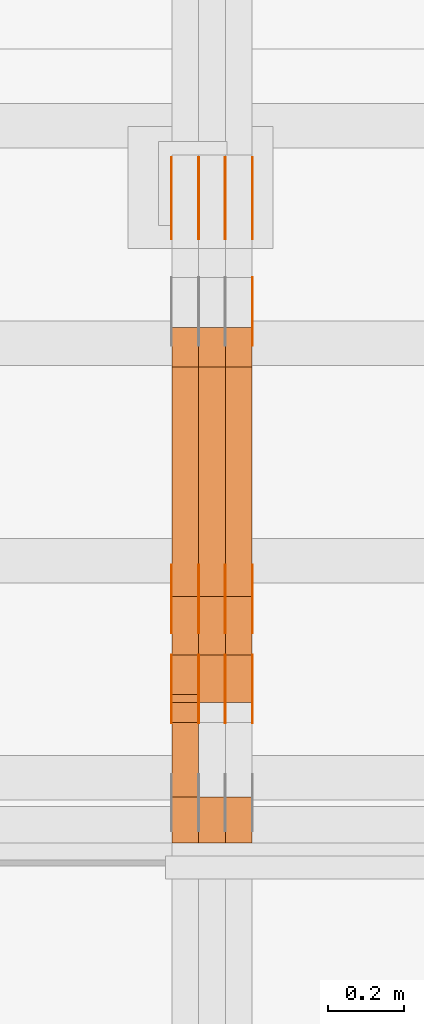
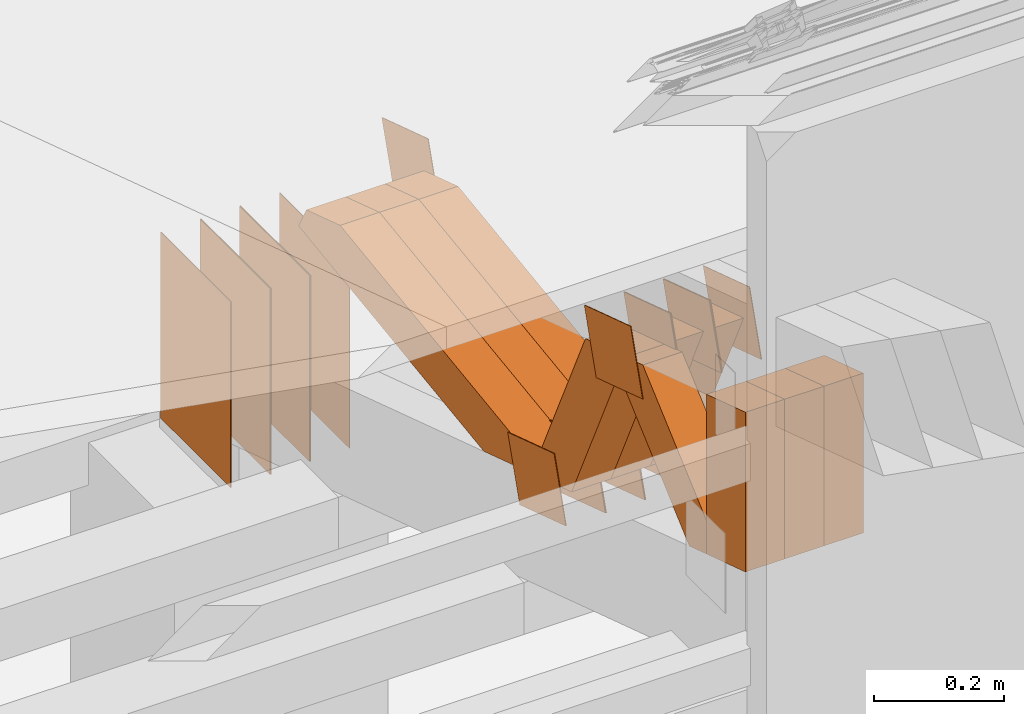
# One storey, part 167 of 385: 29 proxies.
"""IFC2X3 building model written with IfcOpenShell, lengths in millimetres."""

import ifcopenshell
import ifcopenshell.guid

model = None  # the IFC model being written
_history = None  # IfcOwnerHistory: only IFC2X3 demands one
_inside = {}  # id of a spatial element -> (the spatial element, [elements in it])
_under = {}  # id of a project, library or spatial element -> (it, [spatial elements below it])
_declared = {}  # id of a project -> (the project, [libraries it declares])
_typed = {}  # id of a type object -> (the type object, [elements of that type])
_made_of = {}  # id of a material, layer set ... -> (it, [elements and type objects made of it])


def new_model(schema):
    """Start an empty IFC model of exactly this schema.

    Asked for "IFC4X3", IfcOpenShell would pick the latest addendum, in which some entities
    have other attributes; the version numbers below select the first issue.
    IFC2X3 requires an IfcOwnerHistory on every rooted entity: one is made here for all.
    """
    global model, _history
    if schema == "IFC4X3":
        model = ifcopenshell.file(schema_version=(4, 3, 0, 0))
    else:
        model = ifcopenshell.file(schema=schema)
    _inside.clear()
    _under.clear()
    _declared.clear()
    _typed.clear()
    _made_of.clear()
    _history = None
    if model.schema == "IFC2X3":
        org = make("IfcOrganization", Name="unknown")
        user = make(
            "IfcPersonAndOrganization",
            ThePerson=make("IfcPerson", FamilyName="unknown"),
            TheOrganization=org,
        )
        app = make(
            "IfcApplication",
            ApplicationDeveloper=org,
            Version="unknown",
            ApplicationFullName="unknown",
            ApplicationIdentifier="unknown",
        )
        _history = make(
            "IfcOwnerHistory",
            OwningUser=user,
            OwningApplication=app,
            ChangeAction="ADDED",
            CreationDate=0,
        )
    return model


def make(cls, **values):
    """One entity of the class cls with the attributes given. An attribute that is None is left unset."""
    return model.create_entity(
        cls, **{name: value for name, value in values.items() if value is not None}
    )


def entity(cls, *values):
    """Any entity or typed value of the class cls, its attributes in the order of the schema. None: left unset."""
    e = model.create_entity(cls)
    for i, value in enumerate(values):
        if value is not None:
            e[i] = value
    return e


def rooted(cls, **values):
    """An entity with a GlobalId (a new one), such as an element, a storey or a relation."""
    return make(cls, GlobalId=ifcopenshell.guid.new(), OwnerHistory=_history, **values)


def si_unit(unit_type, name, prefix=None):
    """IfcSIUnit, for example si_unit("LENGTHUNIT", "METRE", prefix="MILLI")."""
    return make("IfcSIUnit", UnitType=unit_type, Prefix=prefix, Name=name)


def converted_unit(unit_type, name, factor, base, dimensions=None, offset=None):
    """IfcConversionBasedUnit, such as the inch: factor (a typed value) times the base unit."""
    return make(
        "IfcConversionBasedUnit"
        if offset is None
        else "IfcConversionBasedUnitWithOffset",
        ConversionOffset=offset,
        Dimensions=None
        if dimensions is None
        else entity("IfcDimensionalExponents", *dimensions),
        UnitType=unit_type,
        Name=name,
        ConversionFactor=make(
            "IfcMeasureWithUnit", ValueComponent=factor, UnitComponent=base
        ),
    )


def derived_unit(unit_type, elements):
    """IfcDerivedUnit: a product of units, each with its exponent."""
    return make(
        "IfcDerivedUnit",
        Elements=[
            make("IfcDerivedUnitElement", Unit=unit, Exponent=power)
            for unit, power in elements
        ],
        UnitType=unit_type,
    )


def assignment(units):
    """IfcUnitAssignment: the units of a project."""
    return None if units is None else make("IfcUnitAssignment", Units=units)


def point(xyz):
    """IfcCartesianPoint."""
    return None if xyz is None else make("IfcCartesianPoint", Coordinates=xyz)


def direction(xyz):
    """IfcDirection."""
    return None if xyz is None else make("IfcDirection", DirectionRatios=xyz)


def frame(location, z_axis=None, x_axis=None):
    """IfcAxis2Placement3D, a coordinate frame: its origin and axes. An axis left out is left unset."""
    return make(
        "IfcAxis2Placement3D",
        Location=point(location),
        Axis=direction(z_axis),
        RefDirection=direction(x_axis),
    )


def frame_2d(location, x_axis=None):
    """IfcAxis2Placement2D, a coordinate frame in the plane: its origin and x axis."""
    return make(
        "IfcAxis2Placement2D", Location=point(location), RefDirection=direction(x_axis)
    )


def origin():
    """The frame at (0, 0, 0) with its axes left unset."""
    return frame((0.0, 0.0, 0.0))


def origin_2d_with_axis():
    """The frame at (0, 0) in the plane with the x axis (1, 0) written out."""
    return frame_2d((0.0, 0.0), x_axis=(1.0, 0.0))


def place(relative_to, where):
    """IfcLocalPlacement: puts the frame where relative to a parent placement (None: the world)."""
    return make(
        "IfcLocalPlacement", PlacementRelTo=relative_to, RelativePlacement=where
    )


def context(
    kind, dimensions, precision=None, world=None, true_north=None, identifier=None
):
    """IfcGeometricRepresentationContext, for example the 3D "Model" context."""
    return make(
        "IfcGeometricRepresentationContext",
        ContextIdentifier=identifier,
        ContextType=kind,
        CoordinateSpaceDimension=dimensions,
        Precision=precision,
        WorldCoordinateSystem=world,
        TrueNorth=true_north,
    )


def subcontext(parent, identifier, kind, view, scale=None):
    """IfcGeometricRepresentationSubContext, for example "Body" below "Model"."""
    return make(
        "IfcGeometricRepresentationSubContext",
        ContextIdentifier=identifier,
        ContextType=kind,
        ParentContext=parent,
        TargetScale=scale,
        TargetView=view,
    )


def project(units=None, contexts=None):
    """IfcProject with its units and contexts."""
    return rooted(
        "IfcProject",
        Name="project",
        RepresentationContexts=contexts,
        UnitsInContext=assignment(units),
    )


def spatial(cls, under=None, at=None, **own):
    """A site, building, storey or space (cls), placed at a placement, below another one or the project."""
    s = rooted(cls, ObjectPlacement=at, **own)
    if under is not None:
        _under.setdefault(under.id(), (under, []))[1].append(s)
    return s


def polyline(points):
    """IfcPolyline through the points."""
    return make("IfcPolyline", Points=[point(p) for p in points])


def profile(cls, at=None, kind="AREA", **sizes):
    """A parametric profile (cls). Its sizes go by their IFC names, for example OverallWidth=200.0."""
    return make(cls, ProfileType=kind, Position=at, **sizes)


def rectangle(**sizes):
    """IfcRectangleProfileDef."""
    return profile("IfcRectangleProfileDef", **sizes)


def outline(outer, holes=None, kind="AREA"):
    """IfcArbitraryClosedProfileDef: a profile drawn as a closed curve; with holes, ...WithVoids."""
    if holes is None:
        return make("IfcArbitraryClosedProfileDef", ProfileType=kind, OuterCurve=outer)
    return make(
        "IfcArbitraryProfileDefWithVoids",
        ProfileType=kind,
        OuterCurve=outer,
        InnerCurves=holes,
    )


def extrude(swept, where, along, depth):
    """IfcExtrudedAreaSolid: the profile swept, set in the frame where, extruded along a direction by depth."""
    return make(
        "IfcExtrudedAreaSolid",
        SweptArea=swept,
        Position=where,
        ExtrudedDirection=direction(along),
        Depth=depth,
    )


def shape(context_of_items, identifier, shape_type, items):
    """IfcShapeRepresentation: the items that make up one representation, for example the "Body"."""
    return make(
        "IfcShapeRepresentation",
        ContextOfItems=context_of_items,
        RepresentationIdentifier=identifier,
        RepresentationType=shape_type,
        Items=items,
    )


def source(mapping_origin, context_of_items, identifier, shape_type, items):
    """IfcRepresentationMap: a shape defined once, which mapped items show again and again."""
    return make(
        "IfcRepresentationMap",
        MappingOrigin=mapping_origin,
        MappedRepresentation=shape(context_of_items, identifier, shape_type, items),
    )


def transform(
    local_origin,
    x_axis=None,
    y_axis=None,
    z_axis=None,
    scale=None,
    scale2=None,
    scale3=None,
    uniform=True,
):
    """IfcCartesianTransformationOperator3D, or its non-uniform kind. x_axis, y_axis, z_axis: its Axis1, 2, 3."""
    if uniform:
        return make(
            "IfcCartesianTransformationOperator3D",
            Axis1=direction(x_axis),
            Axis2=direction(y_axis),
            LocalOrigin=point(local_origin),
            Scale=scale,
            Axis3=direction(z_axis),
        )
    return make(
        "IfcCartesianTransformationOperator3DnonUniform",
        Axis1=direction(x_axis),
        Axis2=direction(y_axis),
        LocalOrigin=point(local_origin),
        Scale=scale,
        Axis3=direction(z_axis),
        Scale2=scale2,
        Scale3=scale3,
    )


def mapped(mapping_source, mapping_target):
    """IfcMappedItem: shows the shape of a source again, moved by a transform."""
    return make(
        "IfcMappedItem", MappingSource=mapping_source, MappingTarget=mapping_target
    )


def material(Name=None, Category=None):
    """IfcMaterial."""
    return make("IfcMaterial", Name=Name, Category=Category)


def made_of(thing, what):
    """Note that an element or type object is made of a material, layer set ...; save() writes the relation."""
    if what is not None:
        _made_of.setdefault(what.id(), (what, []))[1].append(thing)
    return thing


def type_object(cls, material=None, **own):
    """A type object (cls), such as IfcWallType, which elements share."""
    return made_of(rooted(cls, **own), material)


def type_shapes(of_type, sources):
    """Give a type object the sources (RepresentationMaps) that its elements show as mapped items."""
    of_type.RepresentationMaps = sources


def element(
    cls,
    number,
    at=None,
    inside=None,
    cuts=None,
    type_object=None,
    material=None,
    context=None,
    identifier="Body",
    shape_type=None,
    held_by="IfcProductDefinitionShape",
    body=None,
    shapes=None,
    **own,
):
    """One element of the class cls, such as IfcWall. Its Tag is "e" and its number.

    at: its placement. inside: the storey or other place that contains it. cuts: it is an
    opening in that element (IfcRelVoidsElement). A single representation is given by context,
    identifier, shape_type and body (its items); several are given by shapes. held_by: the class
    of the entity that holds the representations. save() writes the other relations.
    """
    e = rooted(cls, Tag="e%d" % number, ObjectPlacement=at, **own)
    if body is not None:
        shapes = [shape(context, identifier, shape_type, body)]
    if shapes is not None:
        e.Representation = make(held_by, Representations=shapes)
    if inside is not None:
        _inside.setdefault(inside.id(), (inside, []))[1].append(e)
    if cuts is not None:
        rooted(
            "IfcRelVoidsElement", RelatingBuildingElement=cuts, RelatedOpeningElement=e
        )
    if type_object is not None:
        _typed.setdefault(type_object.id(), (type_object, []))[1].append(e)
    return made_of(e, material)


def aggregate(whole, parts):
    """IfcRelAggregates: a whole, such as a stair, and the parts it consists of."""
    return rooted("IfcRelAggregates", RelatingObject=whole, RelatedObjects=parts)


def save(model, path):
    """Write the relations noted so far, then the file.

    IfcRelAggregates (storeys below a building ...), IfcRelContainedInSpatialStructure (elements
    in a storey), IfcRelDefinesByType, IfcRelAssociatesMaterial and IfcRelDeclares: one each for
    every whole, place, type object, material and project.
    """
    for whole, parts in _under.values():
        aggregate(whole, parts)
    for where, things in _inside.values():
        rooted(
            "IfcRelContainedInSpatialStructure",
            RelatedElements=things,
            RelatingStructure=where,
        )
    for kind, things in _typed.values():
        rooted("IfcRelDefinesByType", RelatedObjects=things, RelatingType=kind)
    for what, things in _made_of.values():
        rooted("IfcRelAssociatesMaterial", RelatedObjects=things, RelatingMaterial=what)
    for by, libraries in _declared.values():
        rooted("IfcRelDeclares", RelatingContext=by, RelatedDefinitions=libraries)
    model.write(path)


model = new_model("IFC2X3")

# Units and contexts
model_context = context("Model", 3, precision=0.01, world=origin(), true_north=direction((6.12303176911189e-17, 1.0)))
body_context = subcontext(model_context, "Body", "Model", "MODEL_VIEW")
ifc_project = project(units=[si_unit("LENGTHUNIT", "METRE", prefix="MILLI"), si_unit("AREAUNIT", "SQUARE_METRE"), si_unit("VOLUMEUNIT", "CUBIC_METRE"), converted_unit("PLANEANGLEUNIT", "DEGREE", entity("IfcRatioMeasure", 0.0174532925199433), si_unit("PLANEANGLEUNIT", "RADIAN"), dimensions=[0, 0, 0, 0, 0, 0, 0]), si_unit("MASSUNIT", "GRAM", prefix="KILO"), derived_unit("MASSDENSITYUNIT", [(si_unit("MASSUNIT", "GRAM", prefix="KILO"), 1), (si_unit("LENGTHUNIT", "METRE"), -3)]), si_unit("TIMEUNIT", "SECOND"), si_unit("FREQUENCYUNIT", "HERTZ"), si_unit("THERMODYNAMICTEMPERATUREUNIT", "DEGREE_CELSIUS"), derived_unit("THERMALTRANSMITTANCEUNIT", [(si_unit("MASSUNIT", "GRAM", prefix="KILO"), 1), (si_unit("THERMODYNAMICTEMPERATUREUNIT", "KELVIN"), -1), (si_unit("TIMEUNIT", "SECOND"), -3)]), derived_unit("VOLUMETRICFLOWRATEUNIT", [(si_unit("LENGTHUNIT", "METRE"), 3), (si_unit("TIMEUNIT", "SECOND"), -1)]), si_unit("ELECTRICCURRENTUNIT", "AMPERE"), si_unit("ELECTRICVOLTAGEUNIT", "VOLT"), si_unit("POWERUNIT", "WATT"), si_unit("FORCEUNIT", "NEWTON", prefix="KILO"), si_unit("ILLUMINANCEUNIT", "LUX"), si_unit("LUMINOUSFLUXUNIT", "LUMEN"), si_unit("LUMINOUSINTENSITYUNIT", "CANDELA"), derived_unit("USERDEFINED", [(si_unit("MASSUNIT", "GRAM", prefix="KILO"), -1), (si_unit("LENGTHUNIT", "METRE"), -2), (si_unit("TIMEUNIT", "SECOND"), 3), (si_unit("LUMINOUSFLUXUNIT", "LUMEN"), 1)]), derived_unit("LINEARVELOCITYUNIT", [(si_unit("LENGTHUNIT", "METRE"), 1), (si_unit("TIMEUNIT", "SECOND"), -1)]), si_unit("PRESSUREUNIT", "PASCAL"), derived_unit("USERDEFINED", [(si_unit("LENGTHUNIT", "METRE"), -2), (si_unit("MASSUNIT", "GRAM", prefix="KILO"), 1), (si_unit("TIMEUNIT", "SECOND"), -2)])], contexts=[model_context])

# Site, building, storey
site_placement = place(None, origin())
site = spatial("IfcSite", under=ifc_project, at=site_placement, CompositionType="ELEMENT")
building_placement = place(site_placement, origin())
building = spatial("IfcBuilding", under=site, at=building_placement, CompositionType="ELEMENT")
storey_placement = place(building_placement, origin())
storey = spatial("IfcBuildingStorey", under=building, at=storey_placement, Name="Default", CompositionType="ELEMENT", Elevation=0.0)

# Proxies
ifc_material_1 = material(Name="IfcSurfaceStyle #377196")
building_element_proxy_type_1 = type_object("IfcBuildingElementProxyType", PredefinedType="NOTDEFINED", material=ifc_material_1)
shared_shape_1 = source(origin(), body_context, "Body", "SweptSolid", [
    extrude(outline(polyline([(-74.9998605591118, -59.9999264677601), (74.9998754286171, -59.9999264677601), (74.9998605591118, 59.9999264677602), (-74.9998754286171, 59.9999264677602), (-74.9998605591118, -59.9999264677601)])), frame((74.9998754286171, 60.0000503992849, 0.0), z_axis=(0.0, 0.0, 1.0), x_axis=(-1.0, 0.0, 0.0)), (0.0, 0.0, 1.0), 1.3),
])
type_shapes(building_element_proxy_type_1, [shared_shape_1])
proxy_1_placement = place(building_placement, frame((30386.3, 16352.8320303235, 3323.23212676408), z_axis=(-1.0, 0.0, 0.0), x_axis=(0.0, -0.951056516295124, 0.309016994375039)))
element("IfcBuildingElementProxy", 1, at=proxy_1_placement, inside=storey, type_object=building_element_proxy_type_1, material=ifc_material_1, context=body_context, shape_type="MappedRepresentation", body=[
    mapped(shared_shape_1, transform((0.0, 0.0, 0.0), scale=1.0)),
])
ifc_material_2 = material(Name="IfcSurfaceStyle #377139")
building_element_proxy_type_2 = type_object("IfcBuildingElementProxyType", PredefinedType="NOTDEFINED", material=ifc_material_2)
shared_shape_2 = source(origin(), body_context, "Body", "SweptSolid", [
    extrude(outline(polyline([(-74.9998605591118, -59.9999264677601), (74.9998754286171, -59.9999264677601), (74.9998605591118, 59.9999264677602), (-74.9998754286171, 59.9999264677602), (-74.9998605591118, -59.9999264677601)])), frame((74.9998754286171, 60.0000503992849, 0.0), z_axis=(0.0, 0.0, 1.0), x_axis=(-1.0, 0.0, 0.0)), (0.0, 0.0, 1.0), 1.3),
])
type_shapes(building_element_proxy_type_2, [shared_shape_2])
proxy_2_placement = place(building_placement, frame((30315.0, 16352.8320303235, 3323.23212676408), z_axis=(-1.0, 0.0, 0.0), x_axis=(0.0, -0.951056516295124, 0.309016994375039)))
element("IfcBuildingElementProxy", 2, at=proxy_2_placement, inside=storey, type_object=building_element_proxy_type_2, material=ifc_material_2, context=body_context, shape_type="MappedRepresentation", body=[
    mapped(shared_shape_2, transform((0.0, 0.0, 0.0), scale=1.0)),
])
ifc_material_3 = material(Name="IfcSurfaceStyle #377082")
building_element_proxy_type_3 = type_object("IfcBuildingElementProxyType", PredefinedType="NOTDEFINED", material=ifc_material_3)
shared_shape_3 = source(origin(), body_context, "Body", "SweptSolid", [
    extrude(outline(polyline([(-74.9998605591118, -59.9999264677601), (74.9998754286171, -59.9999264677601), (74.9998605591118, 59.9999264677602), (-74.9998754286171, 59.9999264677602), (-74.9998605591118, -59.9999264677601)])), frame((74.9998754286171, 60.0000503992849, 0.0), z_axis=(0.0, 0.0, 1.0), x_axis=(-1.0, 0.0, 0.0)), (0.0, 0.0, 1.0), 1.3),
])
type_shapes(building_element_proxy_type_3, [shared_shape_3])
proxy_3_placement = place(building_placement, frame((30316.3, 16352.8320303235, 3323.23212676408), z_axis=(-1.0, 0.0, 0.0), x_axis=(0.0, -0.951056516295124, 0.309016994375039)))
element("IfcBuildingElementProxy", 3, at=proxy_3_placement, inside=storey, type_object=building_element_proxy_type_3, material=ifc_material_3, context=body_context, shape_type="MappedRepresentation", body=[
    mapped(shared_shape_3, transform((0.0, 0.0, 0.0), scale=1.0)),
])
ifc_material_4 = material(Name="IfcSurfaceStyle #377025")
building_element_proxy_type_4 = type_object("IfcBuildingElementProxyType", PredefinedType="NOTDEFINED", material=ifc_material_4)
shared_shape_4 = source(origin(), body_context, "Body", "SweptSolid", [
    extrude(outline(polyline([(-74.9998605591118, -59.9999264677601), (74.9998754286171, -59.9999264677601), (74.9998605591118, 59.9999264677602), (-74.9998754286171, 59.9999264677602), (-74.9998605591118, -59.9999264677601)])), frame((74.9998754286171, 60.0000503992849, 0.0), z_axis=(0.0, 0.0, 1.0), x_axis=(-1.0, 0.0, 0.0)), (0.0, 0.0, 1.0), 1.29999999999999),
])
type_shapes(building_element_proxy_type_4, [shared_shape_4])
proxy_4_placement = place(building_placement, frame((30245.0, 16352.8320303235, 3323.23212676408), z_axis=(-1.0, 0.0, 0.0), x_axis=(0.0, -0.951056516295124, 0.309016994375039)))
element("IfcBuildingElementProxy", 4, at=proxy_4_placement, inside=storey, type_object=building_element_proxy_type_4, material=ifc_material_4, context=body_context, shape_type="MappedRepresentation", body=[
    mapped(shared_shape_4, transform((0.0, 0.0, 0.0), scale=1.0)),
])
ifc_material_5 = material(Name="IfcSurfaceStyle #376968")
building_element_proxy_type_5 = type_object("IfcBuildingElementProxyType", PredefinedType="NOTDEFINED", material=ifc_material_5)
shared_shape_5 = source(origin(), body_context, "Body", "SweptSolid", [
    extrude(outline(polyline([(-74.9998605591118, -59.9999264677601), (74.9998754286171, -59.9999264677601), (74.9998605591118, 59.9999264677602), (-74.9998754286171, 59.9999264677602), (-74.9998605591118, -59.9999264677601)])), frame((74.9998754286171, 60.0000503992849, 0.0), z_axis=(0.0, 0.0, 1.0), x_axis=(-1.0, 0.0, 0.0)), (0.0, 0.0, 1.0), 1.29999999999999),
])
type_shapes(building_element_proxy_type_5, [shared_shape_5])
proxy_5_placement = place(building_placement, frame((30246.3, 16352.8320303235, 3323.23212676408), z_axis=(-1.0, 0.0, 0.0), x_axis=(0.0, -0.951056516295124, 0.309016994375039)))
element("IfcBuildingElementProxy", 5, at=proxy_5_placement, inside=storey, type_object=building_element_proxy_type_5, material=ifc_material_5, context=body_context, shape_type="MappedRepresentation", body=[
    mapped(shared_shape_5, transform((0.0, 0.0, 0.0), scale=1.0)),
])
ifc_material_6 = material(Name="IfcSurfaceStyle #376911")
building_element_proxy_type_6 = type_object("IfcBuildingElementProxyType", PredefinedType="NOTDEFINED", material=ifc_material_6)
shared_shape_6 = source(origin(), body_context, "Body", "SweptSolid", [
    extrude(outline(polyline([(-74.9998605591118, -59.9999264677601), (74.9998754286171, -59.9999264677601), (74.9998605591118, 59.9999264677602), (-74.9998754286171, 59.9999264677602), (-74.9998605591118, -59.9999264677601)])), frame((74.9998754286171, 60.0000503992849, 0.0), z_axis=(0.0, 0.0, 1.0), x_axis=(-1.0, 0.0, 0.0)), (0.0, 0.0, 1.0), 1.29999999999999),
])
type_shapes(building_element_proxy_type_6, [shared_shape_6])
proxy_6_placement = place(building_placement, frame((30175.0, 16352.8320303235, 3323.23212676408), z_axis=(-1.0, 0.0, 0.0), x_axis=(0.0, -0.951056516295124, 0.309016994375039)))
element("IfcBuildingElementProxy", 6, at=proxy_6_placement, inside=storey, type_object=building_element_proxy_type_6, material=ifc_material_6, context=body_context, shape_type="MappedRepresentation", body=[
    mapped(shared_shape_6, transform((0.0, 0.0, 0.0), scale=1.0)),
])
ifc_material_7 = material(Name="IfcSurfaceStyle #374802")
building_element_proxy_type_7 = type_object("IfcBuildingElementProxyType", PredefinedType="NOTDEFINED", material=ifc_material_7)
shared_shape_7 = source(origin(), body_context, "Body", "SweptSolid", [
    extrude(rectangle(XDim=350.0, YDim=215.999999999984, at=origin_2d_with_axis()), frame((175.0, 108.0, 0.0), z_axis=(0.0, 0.0, 1.0), x_axis=(-1.0, 0.0, 0.0)), (0.0, 0.0, 1.0), 1.29999999999999),
])
type_shapes(building_element_proxy_type_7, [shared_shape_7])
proxy_7_placement = place(building_placement, frame((30386.3, 17459.2939453125, 3165.36425781251), z_axis=(-1.0, 0.0, 0.0), x_axis=(0.0, 0.0, -1.0)))
element("IfcBuildingElementProxy", 7, at=proxy_7_placement, inside=storey, type_object=building_element_proxy_type_7, material=ifc_material_7, context=body_context, shape_type="MappedRepresentation", body=[
    mapped(shared_shape_7, transform((0.0, 0.0, 0.0), scale=1.0)),
])
ifc_material_8 = material(Name="IfcSurfaceStyle #374745")
building_element_proxy_type_8 = type_object("IfcBuildingElementProxyType", PredefinedType="NOTDEFINED", material=ifc_material_8)
shared_shape_8 = source(origin(), body_context, "Body", "SweptSolid", [
    extrude(rectangle(XDim=350.0, YDim=215.999999999984, at=origin_2d_with_axis()), frame((175.0, 108.0, 0.0), z_axis=(0.0, 0.0, 1.0), x_axis=(-1.0, 0.0, 0.0)), (0.0, 0.0, 1.0), 1.29999999999999),
])
type_shapes(building_element_proxy_type_8, [shared_shape_8])
proxy_8_placement = place(building_placement, frame((30315.0, 17459.2939453125, 3165.36425781251), z_axis=(-1.0, 0.0, 0.0), x_axis=(0.0, 0.0, -1.0)))
element("IfcBuildingElementProxy", 8, at=proxy_8_placement, inside=storey, type_object=building_element_proxy_type_8, material=ifc_material_8, context=body_context, shape_type="MappedRepresentation", body=[
    mapped(shared_shape_8, transform((0.0, 0.0, 0.0), scale=1.0)),
])
ifc_material_9 = material(Name="IfcSurfaceStyle #374688")
building_element_proxy_type_9 = type_object("IfcBuildingElementProxyType", PredefinedType="NOTDEFINED", material=ifc_material_9)
shared_shape_9 = source(origin(), body_context, "Body", "SweptSolid", [
    extrude(rectangle(XDim=350.0, YDim=215.999999999984, at=origin_2d_with_axis()), frame((175.0, 108.0, 0.0), z_axis=(0.0, 0.0, 1.0), x_axis=(-1.0, 0.0, 0.0)), (0.0, 0.0, 1.0), 1.29999999999999),
])
type_shapes(building_element_proxy_type_9, [shared_shape_9])
proxy_9_placement = place(building_placement, frame((30316.3, 17459.2939453125, 3165.36425781251), z_axis=(-1.0, 0.0, 0.0), x_axis=(0.0, 0.0, -1.0)))
element("IfcBuildingElementProxy", 9, at=proxy_9_placement, inside=storey, type_object=building_element_proxy_type_9, material=ifc_material_9, context=body_context, shape_type="MappedRepresentation", body=[
    mapped(shared_shape_9, transform((0.0, 0.0, 0.0), scale=1.0)),
])
ifc_material_10 = material(Name="IfcSurfaceStyle #374631")
building_element_proxy_type_10 = type_object("IfcBuildingElementProxyType", PredefinedType="NOTDEFINED", material=ifc_material_10)
shared_shape_10 = source(origin(), body_context, "Body", "SweptSolid", [
    extrude(rectangle(XDim=350.0, YDim=215.999999999984, at=origin_2d_with_axis()), frame((175.0, 108.0, 0.0), z_axis=(0.0, 0.0, 1.0), x_axis=(-1.0, 0.0, 0.0)), (0.0, 0.0, 1.0), 1.29999999999998),
])
type_shapes(building_element_proxy_type_10, [shared_shape_10])
proxy_10_placement = place(building_placement, frame((30245.0, 17459.2939453125, 3165.36425781251), z_axis=(-1.0, 0.0, 0.0), x_axis=(0.0, 0.0, -1.0)))
element("IfcBuildingElementProxy", 10, at=proxy_10_placement, inside=storey, type_object=building_element_proxy_type_10, material=ifc_material_10, context=body_context, shape_type="MappedRepresentation", body=[
    mapped(shared_shape_10, transform((0.0, 0.0, 0.0), scale=1.0)),
])
ifc_material_11 = material(Name="IfcSurfaceStyle #374574")
building_element_proxy_type_11 = type_object("IfcBuildingElementProxyType", PredefinedType="NOTDEFINED", material=ifc_material_11)
shared_shape_11 = source(origin(), body_context, "Body", "SweptSolid", [
    extrude(rectangle(XDim=350.0, YDim=215.999999999984, at=origin_2d_with_axis()), frame((175.0, 108.0, 0.0), z_axis=(0.0, 0.0, 1.0), x_axis=(-1.0, 0.0, 0.0)), (0.0, 0.0, 1.0), 1.29999999999998),
])
type_shapes(building_element_proxy_type_11, [shared_shape_11])
proxy_11_placement = place(building_placement, frame((30246.3, 17459.2939453125, 3165.36425781251), z_axis=(-1.0, 0.0, 0.0), x_axis=(0.0, 0.0, -1.0)))
element("IfcBuildingElementProxy", 11, at=proxy_11_placement, inside=storey, type_object=building_element_proxy_type_11, material=ifc_material_11, context=body_context, shape_type="MappedRepresentation", body=[
    mapped(shared_shape_11, transform((0.0, 0.0, 0.0), scale=1.0)),
])
ifc_material_12 = material(Name="IfcSurfaceStyle #374517")
building_element_proxy_type_12 = type_object("IfcBuildingElementProxyType", PredefinedType="NOTDEFINED", material=ifc_material_12)
shared_shape_12 = source(origin(), body_context, "Body", "SweptSolid", [
    extrude(rectangle(XDim=350.0, YDim=215.999999999984, at=origin_2d_with_axis()), frame((175.0, 108.0, 0.0), z_axis=(0.0, 0.0, 1.0), x_axis=(-1.0, 0.0, 0.0)), (0.0, 0.0, 1.0), 1.29999999999998),
])
type_shapes(building_element_proxy_type_12, [shared_shape_12])
proxy_12_placement = place(building_placement, frame((30175.0, 17459.2939453125, 3165.36425781251), z_axis=(-1.0, 0.0, 0.0), x_axis=(0.0, 0.0, -1.0)))
element("IfcBuildingElementProxy", 12, at=proxy_12_placement, inside=storey, type_object=building_element_proxy_type_12, material=ifc_material_12, context=body_context, shape_type="MappedRepresentation", body=[
    mapped(shared_shape_12, transform((0.0, 0.0, 0.0), scale=1.0)),
])
ifc_material_13 = material(Name="IfcSurfaceStyle #372750")
building_element_proxy_type_13 = type_object("IfcBuildingElementProxyType", PredefinedType="NOTDEFINED", material=ifc_material_13)
shared_shape_13 = source(origin(), body_context, "Body", "SweptSolid", [
    extrude(outline(polyline([(-75.0003249421702, -60.0000773549573), (75.0003398116874, -60.0000773549573), (75.0003249421711, 60.0000773549573), (-75.0003398116883, 60.0000773549573), (-75.0003249421702, -60.0000773549573)])), frame((75.0003398116874, 60.0000773549573, 0.0), z_axis=(0.0, 0.0, 1.0), x_axis=(-1.0, 0.0, 0.0)), (0.0, 0.0, 1.0), 1.3),
])
type_shapes(building_element_proxy_type_13, [shared_shape_13])
proxy_13_placement = place(building_placement, frame((30386.3, 16117.0849050545, 3705.49074668796), z_axis=(-1.0, 0.0, 0.0), x_axis=(0.0, -0.951056516295154, 0.309016994374948)))
element("IfcBuildingElementProxy", 13, at=proxy_13_placement, inside=storey, type_object=building_element_proxy_type_13, material=ifc_material_13, context=body_context, shape_type="MappedRepresentation", body=[
    mapped(shared_shape_13, transform((0.0, 0.0, 0.0), scale=1.0)),
])
ifc_material_14 = material(Name="IfcSurfaceStyle #372693")
building_element_proxy_type_14 = type_object("IfcBuildingElementProxyType", PredefinedType="NOTDEFINED", material=ifc_material_14)
shared_shape_14 = source(origin(), body_context, "Body", "SweptSolid", [
    extrude(outline(polyline([(-75.0003249421702, -60.0000773549573), (75.0003398116874, -60.0000773549573), (75.0003249421711, 60.0000773549573), (-75.0003398116883, 60.0000773549573), (-75.0003249421702, -60.0000773549573)])), frame((75.0003398116874, 60.0000773549573, 0.0), z_axis=(0.0, 0.0, 1.0), x_axis=(-1.0, 0.0, 0.0)), (0.0, 0.0, 1.0), 1.3),
])
type_shapes(building_element_proxy_type_14, [shared_shape_14])
proxy_14_placement = place(building_placement, frame((30315.0, 16117.0849050545, 3705.49074668796), z_axis=(-1.0, 0.0, 0.0), x_axis=(0.0, -0.951056516295154, 0.309016994374948)))
element("IfcBuildingElementProxy", 14, at=proxy_14_placement, inside=storey, type_object=building_element_proxy_type_14, material=ifc_material_14, context=body_context, shape_type="MappedRepresentation", body=[
    mapped(shared_shape_14, transform((0.0, 0.0, 0.0), scale=1.0)),
])
ifc_material_15 = material(Name="IfcSurfaceStyle #372636")
building_element_proxy_type_15 = type_object("IfcBuildingElementProxyType", PredefinedType="NOTDEFINED", material=ifc_material_15)
shared_shape_15 = source(origin(), body_context, "Body", "SweptSolid", [
    extrude(outline(polyline([(-75.0003249421702, -60.0000773549573), (75.0003398116874, -60.0000773549573), (75.0003249421711, 60.0000773549573), (-75.0003398116883, 60.0000773549573), (-75.0003249421702, -60.0000773549573)])), frame((75.0003398116874, 60.0000773549573, 0.0), z_axis=(0.0, 0.0, 1.0), x_axis=(-1.0, 0.0, 0.0)), (0.0, 0.0, 1.0), 1.3),
])
type_shapes(building_element_proxy_type_15, [shared_shape_15])
proxy_15_placement = place(building_placement, frame((30316.3, 16117.0849050545, 3705.49074668796), z_axis=(-1.0, 0.0, 0.0), x_axis=(0.0, -0.951056516295154, 0.309016994374948)))
element("IfcBuildingElementProxy", 15, at=proxy_15_placement, inside=storey, type_object=building_element_proxy_type_15, material=ifc_material_15, context=body_context, shape_type="MappedRepresentation", body=[
    mapped(shared_shape_15, transform((0.0, 0.0, 0.0), scale=1.0)),
])
ifc_material_16 = material(Name="IfcSurfaceStyle #372579")
building_element_proxy_type_16 = type_object("IfcBuildingElementProxyType", PredefinedType="NOTDEFINED", material=ifc_material_16)
shared_shape_16 = source(origin(), body_context, "Body", "SweptSolid", [
    extrude(outline(polyline([(-75.0003249421702, -60.0000773549573), (75.0003398116874, -60.0000773549573), (75.0003249421711, 60.0000773549573), (-75.0003398116883, 60.0000773549573), (-75.0003249421702, -60.0000773549573)])), frame((75.0003398116874, 60.0000773549573, 0.0), z_axis=(0.0, 0.0, 1.0), x_axis=(-1.0, 0.0, 0.0)), (0.0, 0.0, 1.0), 1.29999999999999),
])
type_shapes(building_element_proxy_type_16, [shared_shape_16])
proxy_16_placement = place(building_placement, frame((30245.0, 16117.0849050545, 3705.49074668796), z_axis=(-1.0, 0.0, 0.0), x_axis=(0.0, -0.951056516295154, 0.309016994374948)))
element("IfcBuildingElementProxy", 16, at=proxy_16_placement, inside=storey, type_object=building_element_proxy_type_16, material=ifc_material_16, context=body_context, shape_type="MappedRepresentation", body=[
    mapped(shared_shape_16, transform((0.0, 0.0, 0.0), scale=1.0)),
])
ifc_material_17 = material(Name="IfcSurfaceStyle #372522")
building_element_proxy_type_17 = type_object("IfcBuildingElementProxyType", PredefinedType="NOTDEFINED", material=ifc_material_17)
shared_shape_17 = source(origin(), body_context, "Body", "SweptSolid", [
    extrude(outline(polyline([(-75.0003249421702, -60.0000773549573), (75.0003398116874, -60.0000773549573), (75.0003249421711, 60.0000773549573), (-75.0003398116883, 60.0000773549573), (-75.0003249421702, -60.0000773549573)])), frame((75.0003398116874, 60.0000773549573, 0.0), z_axis=(0.0, 0.0, 1.0), x_axis=(-1.0, 0.0, 0.0)), (0.0, 0.0, 1.0), 1.29999999999999),
])
type_shapes(building_element_proxy_type_17, [shared_shape_17])
proxy_17_placement = place(building_placement, frame((30246.3, 16117.0849050545, 3705.49074668796), z_axis=(-1.0, 0.0, 0.0), x_axis=(0.0, -0.951056516295154, 0.309016994374948)))
element("IfcBuildingElementProxy", 17, at=proxy_17_placement, inside=storey, type_object=building_element_proxy_type_17, material=ifc_material_17, context=body_context, shape_type="MappedRepresentation", body=[
    mapped(shared_shape_17, transform((0.0, 0.0, 0.0), scale=1.0)),
])
ifc_material_18 = material(Name="IfcSurfaceStyle #372465")
building_element_proxy_type_18 = type_object("IfcBuildingElementProxyType", PredefinedType="NOTDEFINED", material=ifc_material_18)
shared_shape_18 = source(origin(), body_context, "Body", "SweptSolid", [
    extrude(outline(polyline([(-75.0003249421702, -60.0000773549573), (75.0003398116874, -60.0000773549573), (75.0003249421711, 60.0000773549573), (-75.0003398116883, 60.0000773549573), (-75.0003249421702, -60.0000773549573)])), frame((75.0003398116874, 60.0000773549573, 0.0), z_axis=(0.0, 0.0, 1.0), x_axis=(-1.0, 0.0, 0.0)), (0.0, 0.0, 1.0), 1.29999999999999),
])
type_shapes(building_element_proxy_type_18, [shared_shape_18])
proxy_18_placement = place(building_placement, frame((30175.0, 16117.0849050545, 3705.49074668796), z_axis=(-1.0, 0.0, 0.0), x_axis=(0.0, -0.951056516295154, 0.309016994374948)))
element("IfcBuildingElementProxy", 18, at=proxy_18_placement, inside=storey, type_object=building_element_proxy_type_18, material=ifc_material_18, context=body_context, shape_type="MappedRepresentation", body=[
    mapped(shared_shape_18, transform((0.0, 0.0, 0.0), scale=1.0)),
])
ifc_material_19 = material(Name="IfcSurfaceStyle #371382")
building_element_proxy_type_19 = type_object("IfcBuildingElementProxyType", PredefinedType="NOTDEFINED", material=ifc_material_19)
shared_shape_19 = source(origin(), body_context, "Body", "SweptSolid", [
    extrude(outline(polyline([(-74.9998605591058, -59.9999264677524), (74.999875428623, -59.9999264677524), (74.9998605591068, 59.9999264677524), (-74.9998754286239, 59.9999264677524), (-74.9998605591058, -59.9999264677524)])), frame((75.0002460484325, 60.0000016373508, 0.0), z_axis=(0.0, 0.0, 1.0), x_axis=(-1.0, 0.0, 0.0)), (0.0, 0.0, 1.0), 1.3),
])
type_shapes(building_element_proxy_type_19, [shared_shape_19])
proxy_19_placement = place(building_placement, frame((30386.3, 17107.0599369346, 3383.82825001787), z_axis=(-1.0, 0.0, 0.0), x_axis=(0.0, -0.951056516295154, 0.309016994374948)))
element("IfcBuildingElementProxy", 19, at=proxy_19_placement, inside=storey, type_object=building_element_proxy_type_19, material=ifc_material_19, context=body_context, shape_type="MappedRepresentation", body=[
    mapped(shared_shape_19, transform((0.0, 0.0, 0.0), scale=1.0)),
])
ifc_material_20 = material(Name="IfcSurfaceStyle #362547")
building_element_proxy_type_20 = type_object("IfcBuildingElementProxyType", Name="T1-W50 362545", PredefinedType="NOTDEFINED", material=ifc_material_20)
shared_shape_20 = source(origin(), body_context, "Body", "SweptSolid", [
    extrude(outline(polyline([(-128.56619634284, -47.4999385885712), (133.151257249084, -47.4999385885712), (161.172800006526, -0.000129729183733609), (147.291467726413, 47.500068317755), (-142.513973767368, 47.500068317755), (-170.535354871815, -0.000129729183754689), (-128.56619634284, -47.4999385885712)])), frame((161.17310141218, 47.5001898716564, 0.0), z_axis=(0.0, 0.0, 1.0), x_axis=(-1.0, 0.0, 0.0)), (0.0, 0.0, 1.0), 70.0),
])
type_shapes(building_element_proxy_type_20, [shared_shape_20])
proxy_20_placement = place(building_placement, frame((30245.0, 16060.0297689714, 3761.73994820667), z_axis=(-1.0, 0.0, 0.0), x_axis=(0.0, -0.749388407538668, -0.662130662820156)))
element("IfcBuildingElementProxy", 20, at=proxy_20_placement, inside=storey, type_object=building_element_proxy_type_20, material=ifc_material_20, Name="T1-W50", context=body_context, shape_type="MappedRepresentation", body=[
    mapped(shared_shape_20, transform((0.0, 0.0, 0.0), scale=1.0)),
])
ifc_material_21 = material(Name="IfcSurfaceStyle #362301")
building_element_proxy_type_21 = type_object("IfcBuildingElementProxyType", Name="T1-W2 362299", PredefinedType="NOTDEFINED", material=ifc_material_21)
shared_shape_21 = source(origin(), body_context, "Body", "SweptSolid", [
    extrude(outline(polyline([(-130.705993652344, -60.0), (169.696350097656, -60.0), (130.706115722656, 60.0), (-169.696472167969, 60.0), (-130.705993652344, -60.0)])), frame((169.696429629256, 60.0, 0.0), z_axis=(0.0, 0.0, 1.0), x_axis=(-1.0, 0.0, 0.0)), (0.0, 0.0, 1.0), 70.0),
])
type_shapes(building_element_proxy_type_21, [shared_shape_21])
proxy_21_placement = place(building_placement, frame((30385.0, 15660.0, 3577.70158062465), z_axis=(-1.0, 0.0, 0.0), x_axis=(0.0, 0.0, 1.0)))
element("IfcBuildingElementProxy", 21, at=proxy_21_placement, inside=storey, type_object=building_element_proxy_type_21, material=ifc_material_21, Name="T1-W2", context=body_context, shape_type="MappedRepresentation", body=[
    mapped(shared_shape_21, transform((0.0, 0.0, 0.0), scale=1.0)),
])
ifc_material_22 = material(Name="IfcSurfaceStyle #362244")
building_element_proxy_type_22 = type_object("IfcBuildingElementProxyType", Name="T1-W2 362242", PredefinedType="NOTDEFINED", material=ifc_material_22)
shared_shape_22 = source(origin(), body_context, "Body", "SweptSolid", [
    extrude(outline(polyline([(-130.705993652344, -60.0), (169.696350097656, -60.0), (130.706115722656, 60.0), (-169.696472167969, 60.0), (-130.705993652344, -60.0)])), frame((169.696429629256, 60.0, 0.0), z_axis=(0.0, 0.0, 1.0), x_axis=(-1.0, 0.0, 0.0)), (0.0, 0.0, 1.0), 70.0),
])
type_shapes(building_element_proxy_type_22, [shared_shape_22])
proxy_22_placement = place(building_placement, frame((30315.0, 15660.0, 3577.70158062465), z_axis=(-1.0, 0.0, 0.0), x_axis=(0.0, 0.0, 1.0)))
element("IfcBuildingElementProxy", 22, at=proxy_22_placement, inside=storey, type_object=building_element_proxy_type_22, material=ifc_material_22, Name="T1-W2", context=body_context, shape_type="MappedRepresentation", body=[
    mapped(shared_shape_22, transform((0.0, 0.0, 0.0), scale=1.0)),
])
ifc_material_23 = material(Name="IfcSurfaceStyle #362187")
building_element_proxy_type_23 = type_object("IfcBuildingElementProxyType", Name="T1-W2 362185", PredefinedType="NOTDEFINED", material=ifc_material_23)
shared_shape_23 = source(origin(), body_context, "Body", "SweptSolid", [
    extrude(outline(polyline([(-130.705993652344, -60.0), (169.696350097656, -60.0), (130.706115722656, 60.0), (-169.696472167969, 60.0), (-130.705993652344, -60.0)])), frame((169.696429629256, 60.0, 0.0), z_axis=(0.0, 0.0, 1.0), x_axis=(-1.0, 0.0, 0.0)), (0.0, 0.0, 1.0), 70.0),
])
type_shapes(building_element_proxy_type_23, [shared_shape_23])
proxy_23_placement = place(building_placement, frame((30245.0, 15660.0, 3577.70158062465), z_axis=(-1.0, 0.0, 0.0), x_axis=(0.0, 0.0, 1.0)))
element("IfcBuildingElementProxy", 23, at=proxy_23_placement, inside=storey, type_object=building_element_proxy_type_23, material=ifc_material_23, Name="T1-W2", context=body_context, shape_type="MappedRepresentation", body=[
    mapped(shared_shape_23, transform((0.0, 0.0, 0.0), scale=1.0)),
])
ifc_material_24 = material(Name="IfcSurfaceStyle #362130")
building_element_proxy_type_24 = type_object("IfcBuildingElementProxyType", Name="T1-W44 362128", PredefinedType="NOTDEFINED", material=ifc_material_24)
shared_shape_24 = source(origin(), body_context, "Body", "SweptSolid", [
    extrude(outline(polyline([(-184.551057772692, -47.4997984945814), (177.527112951531, -47.4997984945814), (162.630077773546, -0.000452497529500495), (118.068221667048, 47.5000247433462), (-273.674354619433, 47.5000247433462), (-184.551057772692, -47.4997984945814)])), frame((177.527112951531, 47.5002721629815, 0.0), z_axis=(0.0, 0.0, 1.0), x_axis=(-1.0, 0.0, 0.0)), (0.0, 0.0, 1.0), 70.0),
])
type_shapes(building_element_proxy_type_24, [shared_shape_24])
proxy_24_placement = place(building_placement, frame((30385.0, 16220.4899216004, 3388.98238154171), z_axis=(-1.0, 0.0, 0.0), x_axis=(0.0, -0.425335045192995, 0.905035965766374)))
element("IfcBuildingElementProxy", 24, at=proxy_24_placement, inside=storey, type_object=building_element_proxy_type_24, material=ifc_material_24, Name="T1-W44", context=body_context, shape_type="MappedRepresentation", body=[
    mapped(shared_shape_24, transform((0.0, 0.0, 0.0), scale=1.0)),
])
ifc_material_25 = material(Name="IfcSurfaceStyle #362064")
building_element_proxy_type_25 = type_object("IfcBuildingElementProxyType", Name="T1-W44 362062", PredefinedType="NOTDEFINED", material=ifc_material_25)
shared_shape_25 = source(origin(), body_context, "Body", "SweptSolid", [
    extrude(outline(polyline([(-184.551057772692, -47.4997984945814), (177.527112951531, -47.4997984945814), (162.630077773546, -0.000452497529500495), (118.068221667048, 47.5000247433462), (-273.674354619433, 47.5000247433462), (-184.551057772692, -47.4997984945814)])), frame((177.527112951531, 47.5002721629815, 0.0), z_axis=(0.0, 0.0, 1.0), x_axis=(-1.0, 0.0, 0.0)), (0.0, 0.0, 1.0), 70.0),
])
type_shapes(building_element_proxy_type_25, [shared_shape_25])
proxy_25_placement = place(building_placement, frame((30315.0, 16220.4899216004, 3388.98238154171), z_axis=(-1.0, 0.0, 0.0), x_axis=(0.0, -0.425335045192995, 0.905035965766374)))
element("IfcBuildingElementProxy", 25, at=proxy_25_placement, inside=storey, type_object=building_element_proxy_type_25, material=ifc_material_25, Name="T1-W44", context=body_context, shape_type="MappedRepresentation", body=[
    mapped(shared_shape_25, transform((0.0, 0.0, 0.0), scale=1.0)),
])
ifc_material_26 = material(Name="IfcSurfaceStyle #361998")
building_element_proxy_type_26 = type_object("IfcBuildingElementProxyType", Name="T1-W44 361996", PredefinedType="NOTDEFINED", material=ifc_material_26)
shared_shape_26 = source(origin(), body_context, "Body", "SweptSolid", [
    extrude(outline(polyline([(-184.551057772692, -47.4997984945814), (177.527112951531, -47.4997984945814), (162.630077773546, -0.000452497529500495), (118.068221667048, 47.5000247433462), (-273.674354619433, 47.5000247433462), (-184.551057772692, -47.4997984945814)])), frame((177.527112951531, 47.5002721629815, 0.0), z_axis=(0.0, 0.0, 1.0), x_axis=(-1.0, 0.0, 0.0)), (0.0, 0.0, 1.0), 70.0),
])
type_shapes(building_element_proxy_type_26, [shared_shape_26])
proxy_26_placement = place(building_placement, frame((30245.0, 16220.4899216004, 3388.98238154171), z_axis=(-1.0, 0.0, 0.0), x_axis=(0.0, -0.425335045192995, 0.905035965766374)))
element("IfcBuildingElementProxy", 26, at=proxy_26_placement, inside=storey, type_object=building_element_proxy_type_26, material=ifc_material_26, Name="T1-W44", context=body_context, shape_type="MappedRepresentation", body=[
    mapped(shared_shape_26, transform((0.0, 0.0, 0.0), scale=1.0)),
])
ifc_material_27 = material(Name="IfcSurfaceStyle #361734")
building_element_proxy_type_27 = type_object("IfcBuildingElementProxyType", Name="T1-W8 361732", PredefinedType="NOTDEFINED", material=ifc_material_27)
shared_shape_27 = source(origin(), body_context, "Body", "SweptSolid", [
    extrude(outline(polyline([(-476.725263324644, -47.5001051695965), (180.672765845439, -47.5001051695965), (279.11020091716, -1.03605560390907e-06), (296.793624402619, 47.5001056876243), (-279.851327840575, 47.5001056876243), (-476.725263324644, -47.5001051695965)])), frame((296.793624402619, 47.5001056876243, 0.0), z_axis=(0.0, 0.0, 1.0), x_axis=(-1.0, 0.0, 0.0)), (0.0, 0.0, 1.0), 70.0),
])
type_shapes(building_element_proxy_type_27, [shared_shape_27])
proxy_27_placement = place(building_placement, frame((30385.0, 17036.40625, 3432.97192382813), z_axis=(-1.0, 0.0, 0.0), x_axis=(0.0, -0.990844046556832, -0.135011389900564)))
element("IfcBuildingElementProxy", 27, at=proxy_27_placement, inside=storey, type_object=building_element_proxy_type_27, material=ifc_material_27, Name="T1-W8", context=body_context, shape_type="MappedRepresentation", body=[
    mapped(shared_shape_27, transform((0.0, 0.0, 0.0), scale=1.0)),
])
ifc_material_28 = material(Name="IfcSurfaceStyle #361668")
building_element_proxy_type_28 = type_object("IfcBuildingElementProxyType", Name="T1-W8 361666", PredefinedType="NOTDEFINED", material=ifc_material_28)
shared_shape_28 = source(origin(), body_context, "Body", "SweptSolid", [
    extrude(outline(polyline([(-476.725263324644, -47.5001051695965), (180.672765845439, -47.5001051695965), (279.11020091716, -1.03605560390907e-06), (296.793624402619, 47.5001056876243), (-279.851327840575, 47.5001056876243), (-476.725263324644, -47.5001051695965)])), frame((296.793624402619, 47.5001056876243, 0.0), z_axis=(0.0, 0.0, 1.0), x_axis=(-1.0, 0.0, 0.0)), (0.0, 0.0, 1.0), 70.0),
])
type_shapes(building_element_proxy_type_28, [shared_shape_28])
proxy_28_placement = place(building_placement, frame((30315.0, 17036.40625, 3432.97192382813), z_axis=(-1.0, 0.0, 0.0), x_axis=(0.0, -0.990844046556832, -0.135011389900564)))
element("IfcBuildingElementProxy", 28, at=proxy_28_placement, inside=storey, type_object=building_element_proxy_type_28, material=ifc_material_28, Name="T1-W8", context=body_context, shape_type="MappedRepresentation", body=[
    mapped(shared_shape_28, transform((0.0, 0.0, 0.0), scale=1.0)),
])
ifc_material_29 = material(Name="IfcSurfaceStyle #361602")
building_element_proxy_type_29 = type_object("IfcBuildingElementProxyType", Name="T1-W8 361600", PredefinedType="NOTDEFINED", material=ifc_material_29)
shared_shape_29 = source(origin(), body_context, "Body", "SweptSolid", [
    extrude(outline(polyline([(-476.725263324644, -47.5001051695965), (180.672765845439, -47.5001051695965), (279.11020091716, -1.03605560390907e-06), (296.793624402619, 47.5001056876243), (-279.851327840575, 47.5001056876243), (-476.725263324644, -47.5001051695965)])), frame((296.793624402619, 47.5001056876243, 0.0), z_axis=(0.0, 0.0, 1.0), x_axis=(-1.0, 0.0, 0.0)), (0.0, 0.0, 1.0), 70.0),
])
type_shapes(building_element_proxy_type_29, [shared_shape_29])
proxy_29_placement = place(building_placement, frame((30245.0, 17036.40625, 3432.97192382813), z_axis=(-1.0, 0.0, 0.0), x_axis=(0.0, -0.990844046556832, -0.135011389900564)))
element("IfcBuildingElementProxy", 29, at=proxy_29_placement, inside=storey, type_object=building_element_proxy_type_29, material=ifc_material_29, Name="T1-W8", context=body_context, shape_type="MappedRepresentation", body=[
    mapped(shared_shape_29, transform((0.0, 0.0, 0.0), scale=1.0)),
])

save(model, "model.ifc")
